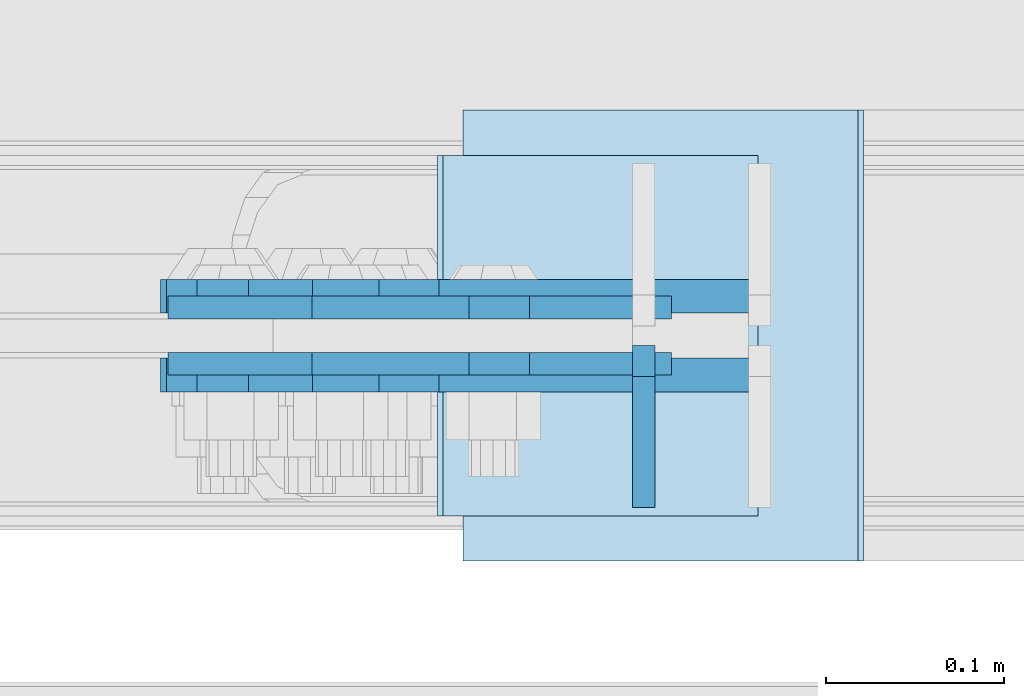
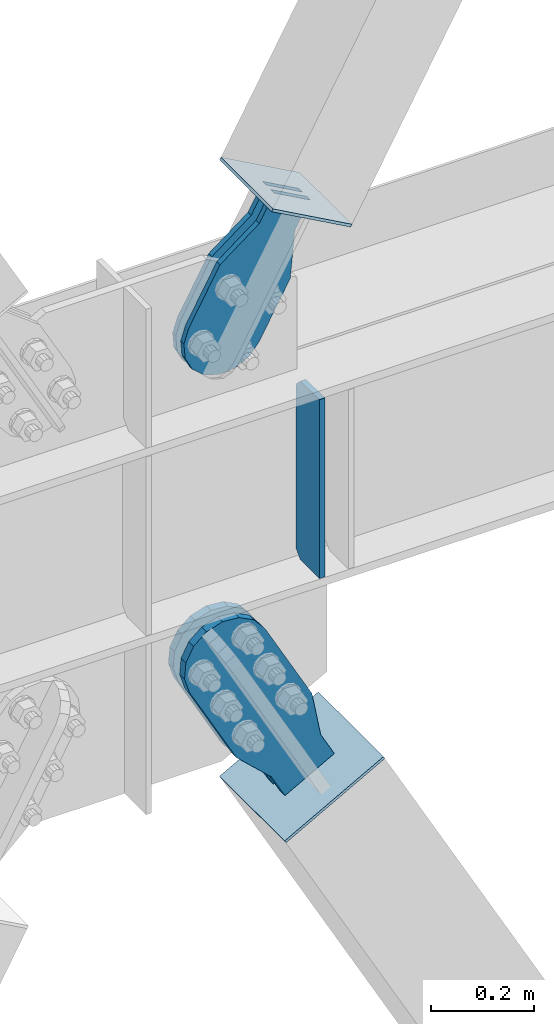
# One storey, part 3529 of 3843: 7 plates, 7 elements without a shape of their own.
"""IFC2X3 building model written with IfcOpenShell, lengths in millimetres."""

from ifc_helpers import new_model, si_unit, frame, origin_with_axes, place, context, subcontext, project, spatial, faceted_brep, material, type_object, element, aggregate, save


model = new_model("IFC2X3")

# Units and contexts
model_context = context("Model", 3, precision=1e-05, world=origin_with_axes())
body_context = subcontext(model_context, "Body", "Model", "MODEL_VIEW")
ifc_project = project(units=[si_unit("LENGTHUNIT", "METRE", prefix="MILLI"), si_unit("AREAUNIT", "SQUARE_METRE"), si_unit("VOLUMEUNIT", "CUBIC_METRE"), si_unit("MASSUNIT", "GRAM", prefix="KILO"), si_unit("TIMEUNIT", "SECOND"), si_unit("PLANEANGLEUNIT", "RADIAN"), si_unit("SOLIDANGLEUNIT", "STERADIAN"), si_unit("THERMODYNAMICTEMPERATUREUNIT", "DEGREE_CELSIUS"), si_unit("LUMINOUSINTENSITYUNIT", "LUMEN")], contexts=[model_context])

# Site, building, storey
site_placement = place(None, origin_with_axes())
site = spatial("IfcSite", under=ifc_project, at=site_placement, CompositionType="ELEMENT")
building_placement = place(site_placement, origin_with_axes())
building = spatial("IfcBuilding", under=site, at=building_placement, Name="Undefined", CompositionType="ELEMENT")
storey_placement = place(building_placement, origin_with_axes())
storey = spatial("IfcBuildingStorey", under=building, at=storey_placement, Name="Undefined", CompositionType="ELEMENT", Elevation=0.0)

# Assembly, plate
assembly_1_placement = place(storey_placement, origin_with_axes())
assembly_1 = element("IfcElementAssembly", 1, at=assembly_1_placement, inside=storey, Name="BEAM", AssemblyPlace="NOTDEFINED", PredefinedType="RIGID_FRAME")
ifc_material_1 = material(Name="STEEL/A572-50")
plate_type_1 = type_object("IfcPlateType", PredefinedType="NOTDEFINED")
plate_1_placement = place(assembly_1_placement, frame((59673.5052972486, 104553.54375, 35990.2125), z_axis=(0.0, -1.0, 0.0), x_axis=(0.0, 0.0, 1.0)))
plate_1 = element("IfcPlate", 2, at=plate_1_placement, type_object=plate_type_1, material=ifc_material_1, Name="CB_BEAM", context=body_context, shape_type="Brep", body=[
    faceted_brep([(0.0, -6.34999999999854, 17.4624996185303), (0.0, -6.34999999999854, 91.28125), (0.0, 6.34999999999854, 91.28125), (0.0, 6.34999999999854, 17.4624996185303), (425.449999999997, -6.34999999999854, 91.28125), (425.449999999997, 6.34999999999854, 91.28125), (425.449999999997, -6.34999999999854, 17.4624996185303), (425.449999999997, 6.34999999999854, 17.4624996185303), (407.987500381467, -6.34999999999854, 0.0), (407.987500381467, 6.34999999999854, 0.0), (17.4624996185303, -6.34999999999854, 0.0), (17.4624996185303, 6.34999999999854, 0.0)], [[[0, 1, 2, 3]], [[1, 4, 5, 2]], [[4, 6, 7, 5]], [[6, 8, 9, 7]], [[8, 10, 11, 9]], [[10, 0, 3, 11]], [[5, 7, 9, 11, 3, 2]], [[10, 8, 6, 4, 1, 0]]]),
])
aggregate(assembly_1, [plate_1])

assembly_2_placement = place(storey_placement, origin_with_axes())
assembly_2 = element("IfcElementAssembly", 3, at=assembly_2_placement, inside=storey, AssemblyPlace="NOTDEFINED", PredefinedType="RIGID_FRAME")
ifc_material_2 = material(Name="STEEL/A36")
plate_type_2 = type_object("IfcPlateType", PredefinedType="NOTDEFINED")
plate_2_placement = place(assembly_2_placement, frame((59655.2504722809, 104574.975, 36777.3505882818), z_axis=(-0.874070462300506, 0.0, 0.485799163167022), x_axis=(0.485799163167024, 0.0, 0.874070462300506)))
plate_2 = element("IfcPlate", 4, at=plate_2_placement, type_object=plate_type_2, material=ifc_material_2, context=body_context, shape_type="Brep", body=[
    faceted_brep([(0.0, -6.3499999046162, 0.0), (-101.599999999482, -6.35000000000582, -44.6881937832222), (-101.599999999482, 6.35000000000582, -44.6881937832222), (7.27595761418343e-12, 6.3499999046162, 0.0), (-246.684985846376, -6.35000000000582, -44.6881937832586), (-246.684985846376, 6.35000000000582, -44.6881937832586), (-281.313054100305, -6.35000000000582, -37.8002427490646), (-281.313054100305, 6.35000000000582, -37.8002427490646), (-310.669312866783, -6.35000000000582, -18.18501775197), (-310.669312866783, 6.35000000000582, -18.18501775197), (-330.284537863758, -6.35000000000582, 11.1712410146756), (-330.284537863758, 6.35000000000582, 11.1712410146756), (-337.172488897893, -6.35000000000582, 45.7993031645856), (-337.172488897893, 6.35000000000582, 45.7993031645856), (-330.284537863699, -6.35000000000582, 80.4273714186893), (-330.284537863699, 6.35000000000582, 80.4273714186893), (-310.669312866681, -6.35000000000582, 109.783630185331), (-310.669312866681, 6.35000000000582, 109.783630185331), (-281.313054100174, -6.35000000000582, 129.39885518244), (-281.313054100174, 6.35000000000582, 129.39885518244), (-246.684988898312, -6.35000000000582, 136.286806216667), (-246.684988898312, 6.35000000000582, 136.286806216667), (-101.599999999322, -6.35000000000582, 136.286806216689), (-101.599999999322, 6.35000000000582, 136.286806216689), (2.18278728425503e-10, -6.35000000000582, 91.5986124321353), (2.18278728425503e-10, 6.35000000000582, 91.5986124321353), (69.8499999987471, -6.35000000000582, 91.598612432037), (69.8499999987471, 6.35000000000582, 91.598612432037), (69.8499999985434, -6.35000000000582, -8.73114913702011e-11), (69.8499999985434, 6.35000000000582, -8.73114913702011e-11)], [[[0, 1, 2, 3]], [[1, 4, 5, 2]], [[4, 6, 7, 5]], [[6, 8, 9, 7]], [[8, 10, 11, 9]], [[10, 12, 13, 11]], [[12, 14, 15, 13]], [[14, 16, 17, 15]], [[16, 18, 19, 17]], [[18, 20, 21, 19]], [[20, 22, 23, 21]], [[22, 24, 25, 23]], [[24, 26, 27, 25]], [[26, 28, 29, 27]], [[28, 0, 3, 29]], [[5, 7, 9, 11, 13, 15, 17, 19, 21, 23, 25, 27, 29, 3, 2]], [[28, 26, 24, 22, 20, 18, 16, 14, 12, 10, 8, 6, 4, 1, 0]]]),
])
aggregate(assembly_2, [plate_2])

assembly_3_placement = place(storey_placement, origin_with_axes())
assembly_3 = element("IfcElementAssembly", 5, at=assembly_3_placement, inside=storey, AssemblyPlace="NOTDEFINED", PredefinedType="RIGID_FRAME")
plate_3_placement = place(assembly_3_placement, frame((59655.2504722809, 104543.225, 36777.3505882818), z_axis=(-0.874070462300506, 0.0, 0.485799163167022), x_axis=(0.485799163167024, 0.0, 0.874070462300506)))
plate_3 = element("IfcPlate", 6, at=plate_3_placement, type_object=plate_type_2, material=ifc_material_2, context=body_context, shape_type="Brep", body=[
    faceted_brep([(0.0, -6.3499999046162, 0.0), (-101.599999999482, -6.35000000000582, -44.6881937832222), (-101.599999999482, 6.35000000000582, -44.6881937832222), (7.27595761418343e-12, 6.3499999046162, 0.0), (-246.684985846376, -6.35000000000582, -44.6881937832586), (-246.684985846376, 6.35000000000582, -44.6881937832586), (-281.313054100305, -6.35000000000582, -37.8002427490646), (-281.313054100305, 6.35000000000582, -37.8002427490646), (-310.669312866783, -6.35000000000582, -18.18501775197), (-310.669312866783, 6.35000000000582, -18.18501775197), (-330.284537863758, -6.35000000000582, 11.1712410146756), (-330.284537863758, 6.35000000000582, 11.1712410146756), (-337.172488897893, -6.35000000000582, 45.7993031645856), (-337.172488897893, 6.35000000000582, 45.7993031645856), (-330.284537863699, -6.35000000000582, 80.4273714186893), (-330.284537863699, 6.35000000000582, 80.4273714186893), (-310.669312866681, -6.35000000000582, 109.783630185331), (-310.669312866681, 6.35000000000582, 109.783630185331), (-281.313054100174, -6.35000000000582, 129.39885518244), (-281.313054100174, 6.35000000000582, 129.39885518244), (-246.684988898312, -6.35000000000582, 136.286806216667), (-246.684988898312, 6.35000000000582, 136.286806216667), (-101.599999999322, -6.35000000000582, 136.286806216689), (-101.599999999322, 6.35000000000582, 136.286806216689), (2.18278728425503e-10, -6.35000000000582, 91.5986124321353), (2.18278728425503e-10, 6.35000000000582, 91.5986124321353), (69.8499999987471, -6.35000000000582, 91.598612432037), (69.8499999987471, 6.35000000000582, 91.598612432037), (69.8499999985434, -6.35000000000582, -8.73114913702011e-11), (69.8499999985434, 6.35000000000582, -8.73114913702011e-11)], [[[0, 1, 2, 3]], [[1, 4, 5, 2]], [[4, 6, 7, 5]], [[6, 8, 9, 7]], [[8, 10, 11, 9]], [[10, 12, 13, 11]], [[12, 14, 15, 13]], [[14, 16, 17, 15]], [[16, 18, 19, 17]], [[18, 20, 21, 19]], [[20, 22, 23, 21]], [[22, 24, 25, 23]], [[24, 26, 27, 25]], [[26, 28, 29, 27]], [[28, 0, 3, 29]], [[5, 7, 9, 11, 13, 15, 17, 19, 21, 23, 25, 27, 29, 3, 2]], [[28, 26, 24, 22, 20, 18, 16, 14, 12, 10, 8, 6, 4, 1, 0]]]),
])
aggregate(assembly_3, [plate_3])

assembly_4_placement = place(storey_placement, origin_with_axes())
assembly_4 = element("IfcElementAssembly", 7, at=assembly_4_placement, inside=storey, Name="Plate", AssemblyPlace="NOTDEFINED", PredefinedType="RIGID_FRAME")
plate_type_3 = type_object("IfcPlateType", PredefinedType="NOTDEFINED")
plate_4_placement = place(assembly_4_placement, frame((59736.4148696937, 104457.5, 36808.5213060071), z_axis=(-0.874070462300506, 0.0, 0.485799163167022), x_axis=(0.0, 1.0, 0.0)))
plate_4 = element("IfcPlate", 8, at=plate_4_placement, type_object=plate_type_3, material=ifc_material_2, Name="Plate", context=body_context, shape_type="Brep", body=[
    faceted_brep([(0.0, -3.17499999999927, 0.0), (0.0, -3.17500000043947, 203.200000001736), (0.0, 3.1749999995518, 203.200000001743), (0.0, 3.17499999999927, 0.0), (203.200000000012, -3.17500000043947, 203.200000001736), (203.200000000012, 3.1749999995518, 203.200000001743), (203.199996948242, -3.17499999999927, 0.0), (203.199996948242, 3.17499999999927, 0.0)], [[[0, 1, 2, 3]], [[1, 4, 5, 2]], [[4, 6, 7, 5]], [[6, 0, 3, 7]], [[5, 7, 3, 2]], [[6, 4, 1, 0]]]),
])
aggregate(assembly_4, [plate_4])

assembly_5_placement = place(storey_placement, origin_with_axes())
assembly_5 = element("IfcElementAssembly", 9, at=assembly_5_placement, inside=storey, AssemblyPlace="NOTDEFINED", PredefinedType="RIGID_FRAME")
plate_type_4 = type_object("IfcPlateType", PredefinedType="NOTDEFINED")
plate_5_placement = place(assembly_5_placement, frame((59707.8942867919, 104581.325, 35565.2058521568), z_axis=(-0.875631045218188, 0.0, -0.482980613120345), x_axis=(0.482980613120343, 0.0, -0.875631045218189)))
plate_5 = element("IfcPlate", 10, at=plate_5_placement, type_object=plate_type_4, material=ifc_material_2, context=body_context, shape_type="Brep", body=[
    faceted_brep([(0.0, -9.52500000000146, 0.0), (-101.599999996755, -9.52499999999418, -33.324272213511), (-101.599999996755, 9.52499999999418, -33.324272213511), (0.0, 9.52500000000146, 0.0), (-320.279297653902, -9.52499999999418, -33.3242722122595), (-320.279297653902, 9.52499999999418, -33.3242722122595), (-357.337405119242, -9.52499999999418, -25.9529563255783), (-357.337405119242, 9.52499999999418, -25.9529563255783), (-388.753751655597, -9.52499999999418, -4.96122468852991), (-388.753751655597, 9.52499999999418, -4.96122468852991), (-409.745483292782, -9.52499999999418, 26.4551218477136), (-409.745483292782, 9.52499999999418, 26.4551218477136), (-417.116799179586, -9.52499999999418, 63.5132262653569), (-417.116799179586, 9.52499999999418, 63.5132262653569), (-409.745483293211, -9.52499999999418, 100.57133373119), (-409.745483293211, 9.52499999999418, 100.57133373119), (-388.753751656006, -9.52499999999418, 131.987680267928), (-388.753751656006, 9.52499999999418, 131.987680267928), (-357.337405119271, -9.52499999999418, 152.97941190518), (-357.337405119271, 9.52499999999418, 152.97941190518), (-320.279299183247, -9.52499999999418, 160.350727791658), (-320.279299183247, 9.52499999999418, 160.350727791658), (-101.599999998418, -9.52499999999418, 160.350727790414), (-101.599999998418, 9.52499999999418, 160.350727790414), (-1.04046193882823e-09, -9.52499999999418, 127.02645557576), (-1.04046193882823e-09, 9.52499999999418, 127.02645557576), (69.8499999968899, -9.52499999999418, 127.026455575353), (69.8499999968899, 9.52499999999418, 127.026455575353), (69.8499999979995, -9.52499999999418, -4.00177668780088e-10), (69.8499999979995, 9.52499999999418, -4.00177668780088e-10)], [[[0, 1, 2, 3]], [[1, 4, 5, 2]], [[4, 6, 7, 5]], [[6, 8, 9, 7]], [[8, 10, 11, 9]], [[10, 12, 13, 11]], [[12, 14, 15, 13]], [[14, 16, 17, 15]], [[16, 18, 19, 17]], [[18, 20, 21, 19]], [[20, 22, 23, 21]], [[22, 24, 25, 23]], [[24, 26, 27, 25]], [[26, 28, 29, 27]], [[28, 0, 3, 29]], [[5, 7, 9, 11, 13, 15, 17, 19, 21, 23, 25, 27, 29, 3, 2]], [[28, 26, 24, 22, 20, 18, 16, 14, 12, 10, 8, 6, 4, 1, 0]]]),
])
aggregate(assembly_5, [plate_5])

assembly_6_placement = place(storey_placement, origin_with_axes())
assembly_6 = element("IfcElementAssembly", 11, at=assembly_6_placement, inside=storey, AssemblyPlace="NOTDEFINED", PredefinedType="RIGID_FRAME")
plate_6_placement = place(assembly_6_placement, frame((59707.8942867919, 104536.875, 35565.2058521568), z_axis=(-0.875631045218188, 0.0, -0.482980613120345), x_axis=(0.482980613120343, 0.0, -0.875631045218189)))
plate_6 = element("IfcPlate", 12, at=plate_6_placement, type_object=plate_type_4, material=ifc_material_2, context=body_context, shape_type="Brep", body=[
    faceted_brep([(0.0, -9.52500000000146, 0.0), (-101.599999996755, -9.52499999999418, -33.324272213511), (-101.599999996755, 9.52499999999418, -33.324272213511), (0.0, 9.52500000000146, 0.0), (-320.279297653902, -9.52499999999418, -33.3242722122595), (-320.279297653902, 9.52499999999418, -33.3242722122595), (-357.337405119242, -9.52499999999418, -25.9529563255783), (-357.337405119242, 9.52499999999418, -25.9529563255783), (-388.753751655597, -9.52499999999418, -4.96122468852991), (-388.753751655597, 9.52499999999418, -4.96122468852991), (-409.745483292782, -9.52499999999418, 26.4551218477136), (-409.745483292782, 9.52499999999418, 26.4551218477136), (-417.116799179586, -9.52499999999418, 63.5132262653569), (-417.116799179586, 9.52499999999418, 63.5132262653569), (-409.745483293211, -9.52499999999418, 100.57133373119), (-409.745483293211, 9.52499999999418, 100.57133373119), (-388.753751656006, -9.52499999999418, 131.987680267928), (-388.753751656006, 9.52499999999418, 131.987680267928), (-357.337405119271, -9.52499999999418, 152.97941190518), (-357.337405119271, 9.52499999999418, 152.97941190518), (-320.279299183247, -9.52499999999418, 160.350727791658), (-320.279299183247, 9.52499999999418, 160.350727791658), (-101.599999998418, -9.52499999999418, 160.350727790414), (-101.599999998418, 9.52499999999418, 160.350727790414), (-1.04046193882823e-09, -9.52499999999418, 127.02645557576), (-1.04046193882823e-09, 9.52499999999418, 127.02645557576), (69.8499999968899, -9.52499999999418, 127.026455575353), (69.8499999968899, 9.52499999999418, 127.026455575353), (69.8499999979995, -9.52499999999418, -4.00177668780088e-10), (69.8499999979995, 9.52499999999418, -4.00177668780088e-10)], [[[0, 1, 2, 3]], [[1, 4, 5, 2]], [[4, 6, 7, 5]], [[6, 8, 9, 7]], [[8, 10, 11, 9]], [[10, 12, 13, 11]], [[12, 14, 15, 13]], [[14, 16, 17, 15]], [[16, 18, 19, 17]], [[18, 20, 21, 19]], [[20, 22, 23, 21]], [[22, 24, 25, 23]], [[24, 26, 27, 25]], [[26, 28, 29, 27]], [[28, 0, 3, 29]], [[5, 7, 9, 11, 13, 15, 17, 19, 21, 23, 25, 27, 29, 3, 2]], [[28, 26, 24, 22, 20, 18, 16, 14, 12, 10, 8, 6, 4, 1, 0]]]),
])
aggregate(assembly_6, [plate_6])

assembly_7_placement = place(storey_placement, origin_with_axes())
assembly_7 = element("IfcElementAssembly", 13, at=assembly_7_placement, inside=storey, Name="Plate", AssemblyPlace="NOTDEFINED", PredefinedType="RIGID_FRAME")
plate_type_5 = type_object("IfcPlateType", PredefinedType="NOTDEFINED")
plate_7_placement = place(assembly_7_placement, frame((59573.2777224122, 104686.1, 35414.8089566371), z_axis=(0.875631045218191, 0.0, 0.482980613120339), x_axis=(0.0, -1.0, 0.0)))
plate_7 = element("IfcPlate", 14, at=plate_7_placement, type_object=plate_type_5, material=ifc_material_2, Name="Plate", context=body_context, shape_type="Brep", body=[
    faceted_brep([(0.0, -3.17499999999927, 0.0), (0.0, -3.17499999965185, 254.000000005151), (0.0, 3.17500000035216, 254.000000005166), (0.0, 3.17499999999927, 0.0), (254.0, -3.17499999965185, 254.000000005151), (254.0, 3.17500000035216, 254.000000005166), (254.0, -3.17500000000291, 0.0), (254.0, 3.17499999999927, 1.45519152283669e-11)], [[[0, 1, 2, 3]], [[1, 4, 5, 2]], [[4, 6, 7, 5]], [[6, 0, 3, 7]], [[5, 7, 3, 2]], [[6, 4, 1, 0]]]),
])
aggregate(assembly_7, [plate_7])

save(model, "model.ifc")
